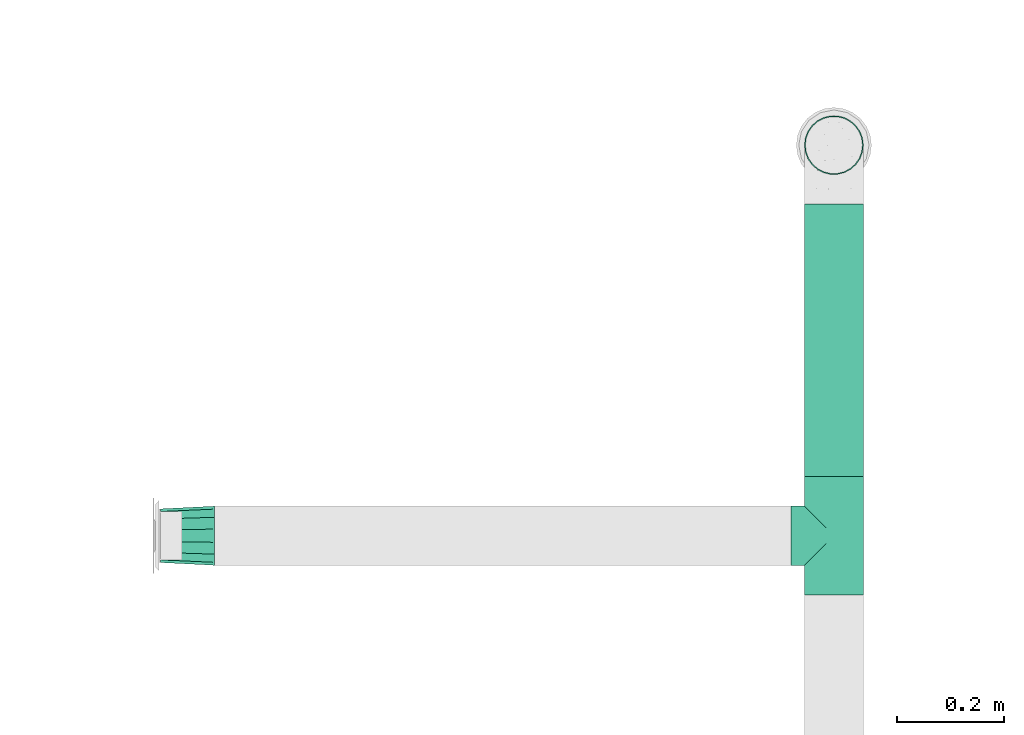
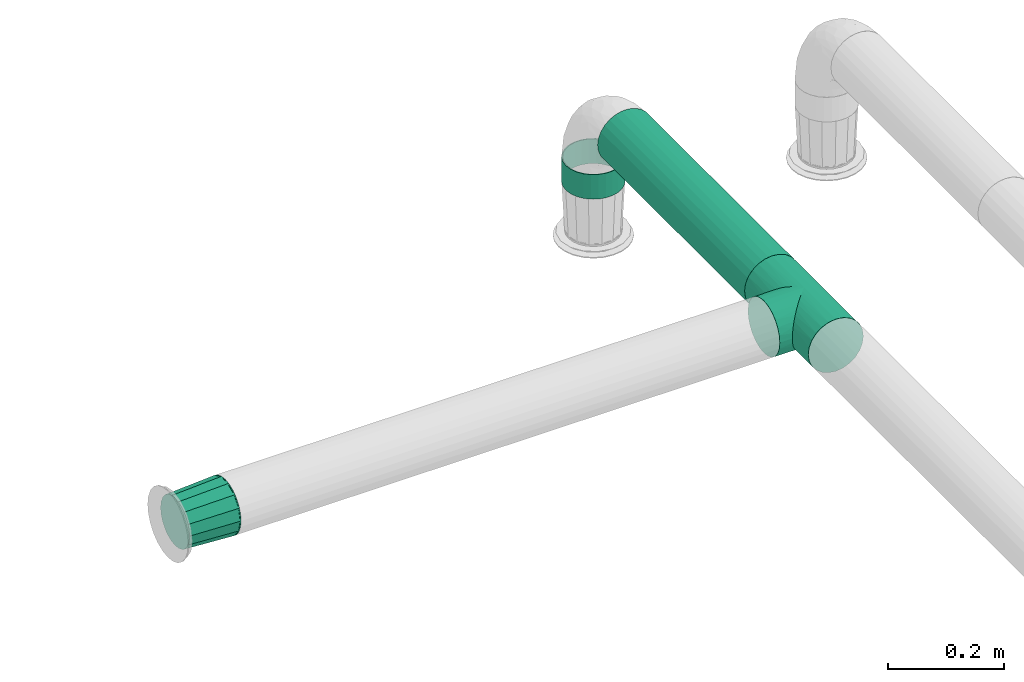
# One storey, part 72 of 115: 2 flow fittings, 2 flow segments.
"""IFC2X3 building model written with IfcOpenShell, lengths in millimetres."""

from ifc_helpers import new_model, entity, si_unit, converted_unit, derived_unit, direction, frame, origin_with_axes, origin_2d_with_axis, place, context, subcontext, project, spatial, hollow_circle, extrude, open_shell, surface_model, source, transform, mapped, material, layer, layer_set, layer_usage, type_object, element, save


model = new_model("IFC2X3")

# Units and contexts
model_context = context("Model", 3, precision=1e-05, world=origin_with_axes(), true_north=direction((0.0, 1.0)))
body_context = subcontext(model_context, "Body", "Model", "MODEL_VIEW")
ifc_project = project(units=[si_unit("AREAUNIT", "SQUARE_METRE"), si_unit("VOLUMEUNIT", "CUBIC_METRE", prefix="DECI"), si_unit("TIMEUNIT", "SECOND"), si_unit("THERMODYNAMICTEMPERATUREUNIT", "DEGREE_CELSIUS"), si_unit("PRESSUREUNIT", "PASCAL"), si_unit("MASSUNIT", "GRAM", prefix="KILO"), si_unit("LENGTHUNIT", "METRE", prefix="MILLI"), si_unit("POWERUNIT", "WATT"), si_unit("ELECTRICCURRENTUNIT", "AMPERE"), si_unit("ELECTRICVOLTAGEUNIT", "VOLT"), derived_unit("VOLUMETRICFLOWRATEUNIT", [(si_unit("VOLUMEUNIT", "CUBIC_METRE", prefix="DECI"), 1), (si_unit("TIMEUNIT", "SECOND"), -1)]), derived_unit("LINEARVELOCITYUNIT", [(si_unit("LENGTHUNIT", "METRE"), 1), (si_unit("TIMEUNIT", "SECOND"), -1)]), derived_unit("MASSDENSITYUNIT", [(si_unit("MASSUNIT", "GRAM", prefix="KILO"), 1), (si_unit("VOLUMEUNIT", "CUBIC_METRE"), -1)]), converted_unit("PLANEANGLEUNIT", "DEGREE", entity("IfcRatioMeasure", 0.01745), si_unit("PLANEANGLEUNIT", "RADIAN"), dimensions=[0, 0, 0, 0, 0, 0, 0])], contexts=[model_context])

# Site, building, storey
site_placement = place(None, origin_with_axes())
site = spatial("IfcSite", under=ifc_project, at=site_placement, CompositionType="ELEMENT")
building_placement = place(site_placement, origin_with_axes())
building = spatial("IfcBuilding", under=site, at=building_placement, Name="mc-building", CompositionType="ELEMENT")
storey_placement = place(building_placement, frame((0.0, 0.0, 2950.0), z_axis=(0.0, 0.0, 1.0), x_axis=(1.0, 0.0, 0.0)))
storey = spatial("IfcBuildingStorey", under=building, at=storey_placement, Name="2. Korrus", CompositionType="ELEMENT", Elevation=2950.0)

# Flow segment
ifc_material = material(Name="FZ1")
ifc_layer = layer(ifc_material, 0.0)
ifc_layer_set = layer_set([ifc_layer], Name="FZ1")
ifc_layer_usage = layer_usage(ifc_layer_set, "AXIS1", "POSITIVE", 0.0)
duct_segment_type = type_object("IfcDuctSegmentType", PredefinedType="RIGIDSEGMENT")
shared_shape_1 = source(origin_with_axes(), body_context, "Body", "SweptSolid", [
    extrude(hollow_circle(Radius=55.0, WallThickness=2.0, at=origin_2d_with_axis()), frame((0.0, 0.0, 0.0), z_axis=(1.0, 0.0, 0.0), x_axis=(0.0, 1.0, 0.0)), (0.0, 0.0, 1.0), 51.9),
])
flow_segment_1_placement = place(storey_placement, frame((30053.28275, 4393.85998, 2355.0), z_axis=(0.0, -1.0, 0.0), x_axis=(0.0, 0.0, -1.0)))
element("IfcFlowSegment", 1, at=flow_segment_1_placement, inside=storey, type_object=duct_segment_type, material=ifc_layer_usage, context=body_context, shape_type="MappedRepresentation", body=[
    mapped(shared_shape_1, transform((0.0, 0.0, 0.0), scale=1.0)),
])

# Flow fittings
duct_fitting_type_1 = type_object("IfcDuctFittingType", PredefinedType="JUNCTION")
shared_shape_2 = source(origin_with_axes(), body_context, "Body", "SurfaceModel", [
    surface_model("IfcShellBasedSurfaceModel", [(-110.0, -38.89087, -38.89087), (-110.0, -55.0, 0.0), (-110.0, -27.5, -47.63139), (-110.0, -53.12592, -14.23505), (-110.0, -47.63139, -27.5), (-110.0, 47.63139, -27.5), (-110.0, 53.12592, 14.23505), (-110.0, 53.12592, -14.23505), (-110.0, 55.0, 0.0), (110.0, 38.89087, -38.89087), (110.0, 55.0, 0.0), (110.0, 27.5, -47.63139), (110.0, -38.89087, -38.89087), (110.0, -53.12592, 14.23505), (110.0, -47.63139, -27.5), (110.0, -55.0, 0.0), (110.0, -53.12592, -14.23505), (110.0, 53.12592, -14.23505), (110.0, 47.63139, -27.5), (-110.0, 38.89087, -38.89087), (-110.0, -14.23505, -53.12592), (-110.0, 0.0, -55.0), (-110.0, 27.5, -47.63139), (-110.0, 14.23505, -53.12592), (-110.0, -53.12592, 14.23505), (-110.0, -47.63139, 27.5), (-110.0, -38.89087, 38.89087), (-110.0, 14.23505, 53.12592), (-110.0, 27.5, 47.63139), (-55.0, 80.0, 0.0), (0.0, 80.0, -55.0), (-14.23505, 80.0, -53.12592), (-27.5, 80.0, -47.63139), (-38.89087, 80.0, -38.89087), (-47.63139, 80.0, -27.5), (38.89087, 80.0, -38.89087), (53.12592, 80.0, 14.23505), (27.5, 80.0, -47.63139), (14.23505, 80.0, -53.12592), (47.63139, 80.0, -27.5), (53.12592, 80.0, -14.23505), (55.0, 80.0, 0.0), (-53.12592, 80.0, -14.23505), (-53.12592, 80.0, 14.23505), (-47.63139, 80.0, 27.5), (-38.89087, 80.0, 38.89087), (0.0, 80.0, 55.0), (-27.5, 80.0, 47.63139), (-14.23505, 80.0, 53.12592), (47.63139, 80.0, 27.5), (38.89087, 80.0, 38.89087), (27.5, 80.0, 47.63139), (14.23505, 80.0, 53.12592), (-7.4066, 7.4066, 54.49901), (0.0, 0.0, 55.0), (-21.93978, 21.93978, 50.43457), (-14.74521, 14.74521, 52.98659), (-35.50357, 35.50357, 42.00591), (-28.89905, 28.89905, 46.79578), (-46.92319, 46.92319, 28.69171), (-41.58668, 41.58668, 35.99373), (-54.01174, 54.01174, 10.37938), (-54.06296, 80.0, 7.11752), (-55.0, 55.0, 0.0), (-51.19777, 51.19777, 20.0945), (-50.37866, 80.0, 20.86752), (-51.19777, 51.19777, -20.0945), (-54.01174, 54.01174, -10.37938), (-50.37866, 80.0, -20.86752), (-41.58668, 41.58668, -35.99373), (-46.92319, 46.92319, -28.69171), (-54.06296, 80.0, -7.11752), (-35.50357, 35.50357, -42.00591), (-14.74521, 14.74521, -52.98659), (-21.93978, 21.93978, -50.43457), (0.0, 0.0, -55.0), (-7.4066, 7.4066, -54.49901), (-28.89905, 28.89905, -46.79578), (7.4066, 7.4066, -54.49901), (21.93978, 21.93978, -50.43457), (14.74521, 14.74521, -52.98659), (35.50357, 35.50357, -42.00591), (28.89905, 28.89905, -46.79578), (46.92319, 46.92319, -28.69171), (41.58668, 41.58668, -35.99373), (54.01174, 54.01174, -10.37938), (54.06296, 80.0, -7.11752), (55.0, 55.0, 0.0), (51.19777, 51.19777, -20.0945), (50.37866, 80.0, -20.86752), (51.19777, 51.19777, 20.0945), (54.01174, 54.01174, 10.37938), (50.37866, 80.0, 20.86752), (41.58668, 41.58668, 35.99373), (46.92319, 46.92319, 28.69171), (54.06296, 80.0, 7.11752), (35.50357, 35.50357, 42.00591), (14.74521, 14.74521, 52.98659), (21.93978, 21.93978, 50.43457), (7.4066, 7.4066, 54.49901), (28.89905, 28.89905, 46.79578), (-110.0, -27.5, 47.63139), (-110.0, 0.0, 55.0), (-110.0, -14.23505, 53.12592), (-110.0, 47.63139, 27.5), (-110.0, 38.89087, 38.89087), (110.0, 0.0, -55.0), (110.0, 14.23505, -53.12592), (110.0, -14.23505, -53.12592), (110.0, -27.5, -47.63139), (110.0, 53.12592, 14.23505), (110.0, -47.63139, 27.5), (110.0, -38.89087, 38.89087), (110.0, 14.23505, 53.12592), (110.0, -27.5, 47.63139), (110.0, -14.23505, 53.12592), (110.0, 47.63139, 27.5), (110.0, 38.89087, 38.89087), (110.0, 27.5, 47.63139), (110.0, 0.0, 55.0)], [open_shell([[[0, 1, 2]], [[3, 1, 4]], [[5, 6, 7]], [[8, 7, 6]], [[9, 10, 11]], [[12, 13, 14]], [[15, 16, 13]], [[17, 10, 18]], [[19, 6, 5]], [[2, 1, 20]], [[19, 21, 6]], [[21, 19, 22]], [[22, 23, 21]], [[24, 25, 21]], [[21, 25, 26]], [[27, 28, 21]], [[29, 30, 31]], [[32, 29, 31]], [[29, 33, 34]], [[29, 32, 33]], [[35, 30, 36]], [[30, 35, 37]], [[37, 38, 30]], [[35, 36, 39]], [[39, 36, 40]], [[41, 40, 36]], [[42, 29, 34]], [[43, 44, 30]], [[30, 44, 45]], [[46, 30, 47]], [[30, 45, 47]], [[46, 47, 48]], [[49, 36, 30]], [[50, 49, 30]], [[51, 50, 30]], [[52, 51, 30]], [[52, 30, 46]], [[29, 43, 30]], [[46, 53, 54]], [[48, 55, 56]], [[48, 56, 53]], [[48, 53, 46]], [[57, 58, 47]], [[55, 48, 47]], [[45, 57, 47]], [[55, 47, 58]], [[44, 59, 60]], [[61, 62, 63]], [[43, 61, 64]], [[65, 43, 64]], [[44, 64, 59]], [[44, 60, 45]], [[43, 62, 61]], [[64, 44, 65]], [[29, 63, 62]], [[57, 45, 60]], [[42, 66, 67]], [[68, 34, 66]], [[34, 69, 70]], [[71, 42, 67]], [[34, 70, 66]], [[63, 71, 67]], [[29, 71, 63]], [[68, 66, 42]], [[34, 33, 69]], [[33, 72, 69]], [[31, 73, 74]], [[30, 75, 76]], [[31, 76, 73]], [[32, 77, 72]], [[77, 32, 74]], [[32, 31, 74]], [[31, 30, 76]], [[33, 32, 72]], [[30, 78, 75]], [[38, 79, 80]], [[38, 80, 78]], [[38, 78, 30]], [[81, 82, 37]], [[79, 38, 37]], [[35, 81, 37]], [[79, 37, 82]], [[39, 83, 84]], [[85, 86, 87]], [[40, 85, 88]], [[89, 40, 88]], [[39, 88, 83]], [[39, 84, 35]], [[40, 86, 85]], [[88, 39, 89]], [[41, 87, 86]], [[81, 35, 84]], [[36, 90, 91]], [[92, 49, 90]], [[49, 93, 94]], [[95, 36, 91]], [[49, 94, 90]], [[87, 95, 91]], [[95, 87, 41]], [[36, 92, 90]], [[49, 50, 93]], [[50, 96, 93]], [[52, 97, 98]], [[46, 54, 99]], [[52, 99, 97]], [[51, 100, 96]], [[100, 51, 98]], [[51, 52, 98]], [[52, 46, 99]], [[50, 51, 96]], [[1, 21, 20]], [[1, 0, 4]], [[101, 102, 26]], [[102, 21, 26]], [[102, 101, 103]], [[104, 6, 21]], [[105, 104, 21]], [[105, 21, 28]], [[21, 102, 27]], [[1, 24, 21]], [[106, 107, 108]], [[108, 13, 109]], [[109, 13, 12]], [[108, 10, 110]], [[107, 11, 10]], [[9, 18, 10]], [[10, 108, 107]], [[16, 14, 13]], [[108, 111, 13]], [[108, 112, 111]], [[108, 113, 114]], [[114, 112, 108]], [[113, 115, 114]], [[108, 110, 116]], [[108, 116, 117]], [[108, 117, 118]], [[113, 108, 118]], [[113, 119, 115]], [[115, 119, 54]], [[114, 115, 101]], [[103, 54, 102]], [[115, 54, 103]], [[103, 101, 115]], [[101, 26, 114]], [[111, 112, 25]], [[13, 111, 24]], [[15, 13, 1]], [[25, 112, 26]], [[24, 111, 25]], [[24, 1, 13]], [[114, 26, 112]], [[16, 15, 3]], [[14, 16, 4]], [[3, 15, 1]], [[4, 16, 3]], [[4, 0, 14]], [[0, 12, 14]], [[109, 12, 2]], [[108, 109, 20]], [[106, 108, 75]], [[20, 109, 2]], [[20, 21, 75]], [[20, 75, 108]], [[0, 2, 12]], [[21, 76, 75]], [[23, 74, 73]], [[23, 73, 76]], [[23, 76, 21]], [[72, 77, 22]], [[74, 23, 22]], [[19, 72, 22]], [[74, 22, 77]], [[5, 70, 69]], [[7, 67, 66]], [[5, 66, 70]], [[5, 69, 19]], [[7, 8, 67]], [[66, 5, 7]], [[63, 67, 8]], [[72, 19, 69]], [[107, 106, 78]], [[79, 11, 107]], [[9, 11, 81]], [[11, 82, 81]], [[106, 75, 78]], [[107, 80, 79]], [[11, 79, 82]], [[80, 107, 78]], [[18, 9, 84]], [[17, 18, 88]], [[10, 17, 85]], [[18, 84, 83]], [[17, 88, 85]], [[10, 85, 87]], [[88, 18, 83]], [[81, 84, 9]], [[110, 10, 91]], [[116, 110, 90]], [[117, 116, 93]], [[10, 87, 91]], [[116, 90, 94]], [[116, 94, 93]], [[90, 110, 91]], [[93, 96, 117]], [[118, 96, 100]], [[117, 96, 118]], [[113, 118, 98]], [[119, 113, 99]], [[118, 100, 98]], [[113, 97, 99]], [[119, 99, 54]], [[97, 113, 98]], [[6, 64, 61]], [[104, 60, 59]], [[104, 59, 64]], [[8, 61, 63]], [[61, 8, 6]], [[6, 104, 64]], [[104, 105, 60]], [[105, 57, 60]], [[27, 56, 55]], [[102, 54, 53]], [[27, 53, 56]], [[28, 58, 57]], [[58, 28, 55]], [[28, 27, 55]], [[27, 102, 53]], [[105, 28, 57]]])]),
])
flow_fitting_1_placement = place(storey_placement, frame((30053.28275, 3666.26111, 2465.0), z_axis=(0.0, 0.0, 1.0), x_axis=(0.0, 1.0, 0.0)))
element("IfcFlowFitting", 2, at=flow_fitting_1_placement, inside=storey, type_object=duct_fitting_type_1, context=body_context, shape_type="MappedRepresentation", body=[
    mapped(shared_shape_2, transform((0.0, 0.0, 0.0), scale=1.0)),
])
duct_fitting_type_2 = type_object("IfcDuctFittingType", PredefinedType="TRANSITION")
shared_shape_3 = source(origin_with_axes(), body_context, "Body", "SurfaceModel", [
    surface_model("IfcShellBasedSurfaceModel", [(100.0, -55.0, 0.0), (100.0, -12.23865, 53.62104), (100.0, -34.29194, 43.00073), (100.0, 49.55329, 23.86361), (100.0, 34.29194, 43.00073), (100.0, 49.55329, -23.86361), (0.0, -45.04844, -21.69419), (0.0, -50.0, 0.0), (0.0, -45.04844, 21.69419), (0.0, 31.17449, 39.09157), (0.0, 45.04844, 21.69419), (0.0, 50.0, 0.0), (98.0, 47.63139, 27.5), (98.0, 0.0, 55.0), (98.0, 38.89087, 38.89087), (98.0, -38.89087, 38.89087), (98.0, -47.63139, 27.5), (100.0, 12.23865, 53.62104), (100.0, -49.55329, 23.86361), (100.0, 55.0, 0.0), (100.0, 12.23865, -53.62104), (100.0, 34.29194, -43.00073), (100.0, -49.55329, -23.86361), (100.0, -34.29194, -43.00073), (100.0, -12.23865, -53.62104), (0.0, -31.17449, 39.09157), (0.0, -11.12605, 48.7464), (0.0, 11.12605, 48.7464), (0.0, -31.17449, -39.09157), (0.0, 11.12605, -48.7464), (0.0, -11.12605, -48.7464), (0.0, 45.04844, -21.69419), (0.0, 31.17449, -39.09157), (0.0, 47.52422, -10.84709), (0.0, 38.11147, -30.39288), (100.0, 41.92261, -33.43217), (100.0, -41.92261, -33.43217), (0.0, -38.11147, -30.39288), (100.0, 23.2653, -48.31088), (0.0, 21.15027, -43.91899), (100.0, 52.32388, -11.72483), (0.0, 0.0, -48.7464), (100.0, 0.0, -53.62104), (0.0, -21.15027, -43.91899), (100.0, -23.2653, -48.31088), (0.0, -47.52422, -10.84709), (100.0, -52.32388, -11.72483), (0.0, -47.52422, 10.84709), (0.0, -38.11147, 30.39288), (100.0, -41.92261, 33.43217), (100.0, 41.92261, 33.43217), (0.0, 38.11147, 30.39288), (100.0, -23.2653, 48.31088), (0.0, -21.15027, 43.91899), (100.0, -52.32388, 11.72483), (0.0, 0.0, 48.7464), (100.0, 0.0, 53.62104), (0.0, 21.15027, 43.91899), (100.0, 23.2653, 48.31088), (0.0, 47.52422, 10.84709), (100.0, 52.32388, 11.72483), (100.0, -14.23505, -53.12592), (100.0, 0.0, -55.0), (100.0, -27.5, -47.63139), (100.0, 27.5, -47.63139), (100.0, -38.89087, -38.89087), (100.0, -53.12592, -14.23505), (100.0, -47.63139, -27.5), (100.0, -47.63139, 27.5), (100.0, 14.23505, -53.12592), (100.0, 38.89087, -38.89087), (100.0, 47.63139, -27.5), (100.0, 47.63139, 27.5), (100.0, 53.12592, -14.23505), (100.0, -53.12592, 14.23505), (100.0, -38.89087, 38.89087), (100.0, -27.5, 47.63139), (100.0, 0.0, 55.0), (100.0, -14.23505, 53.12592), (100.0, 53.12592, 14.23505), (100.0, 38.89087, 38.89087), (100.0, 27.5, 47.63139), (100.0, 14.23505, 53.12592), (98.0, -27.5, 47.63139), (98.0, -14.23505, 53.12592), (98.0, -53.12592, -14.23505), (98.0, 14.23505, 53.12592), (98.0, 27.5, 47.63139), (98.0, 53.12592, 14.23505), (98.0, 55.0, 0.0), (98.0, -47.63139, -27.5), (98.0, -53.12592, 14.23505), (98.0, 27.5, -47.63139), (98.0, -27.5, -47.63139), (98.0, -38.89087, -38.89087), (98.0, 0.0, -55.0), (98.0, -14.23505, -53.12592), (98.0, 38.89087, -38.89087), (98.0, 47.63139, -27.5), (98.0, 53.12592, -14.23505), (98.0, 14.23505, -53.12592), (98.0, -55.0, 0.0), (0.0, 0.0, 50.0), (0.0, 35.35534, 35.35534), (0.0, -12.94095, 48.29629), (0.0, -25.0, 43.30127), (0.0, -35.35534, 35.35534), (0.0, -48.29629, 12.94095), (0.0, -43.30127, 25.0), (0.0, 25.0, 43.30127), (0.0, 12.94095, 48.29629), (0.0, 43.30127, 25.0), (0.0, 48.29629, 12.94095), (0.0, 25.0, -43.30127), (0.0, 48.29629, -12.94095), (0.0, -48.29629, -12.94095), (0.0, -43.30127, -25.0), (0.0, -12.94095, -48.29629), (0.0, -25.0, -43.30127), (0.0, -35.35534, -35.35534), (0.0, 43.30127, -25.0), (0.0, 35.35534, -35.35534), (0.0, 12.94095, -48.29629), (0.0, 0.0, -50.0), (2.0, -35.35534, -35.35534), (2.0, -25.0, -43.30127), (2.0, -12.94095, -48.29629), (2.0, -43.30127, -25.0), (2.0, 0.0, -50.0), (2.0, -48.29629, -12.94095), (2.0, -50.0, 0.0), (2.0, 12.94095, -48.29629), (2.0, 25.0, -43.30127), (2.0, 43.30127, -25.0), (2.0, 48.29629, -12.94095), (2.0, 35.35534, -35.35534), (2.0, -48.29629, 12.94095), (2.0, -35.35534, 35.35534), (2.0, -43.30127, 25.0), (2.0, 35.35534, 35.35534), (2.0, -12.94095, 48.29629), (2.0, -25.0, 43.30127), (2.0, 0.0, 50.0), (2.0, 43.30127, 25.0), (2.0, 48.29629, 12.94095), (2.0, 50.0, 0.0), (2.0, 25.0, 43.30127), (2.0, 12.94095, 48.29629)], [open_shell([[[0, 1, 2]], [[3, 4, 5]], [[6, 7, 8]], [[9, 10, 11]], [[12, 13, 14]], [[15, 13, 16]], [[0, 4, 17]], [[2, 18, 0]], [[1, 0, 17]], [[3, 5, 19]], [[20, 21, 5]], [[22, 20, 5]], [[22, 5, 0]], [[22, 23, 24]], [[22, 24, 20]], [[4, 0, 5]], [[8, 25, 6]], [[6, 25, 26]], [[6, 26, 27]], [[11, 27, 9]], [[28, 6, 29]], [[30, 28, 29]], [[31, 6, 11]], [[31, 32, 29]], [[31, 29, 6]], [[27, 11, 6]], [[31, 33, 5]], [[34, 35, 32]], [[36, 22, 6]], [[36, 37, 23]], [[38, 29, 39]], [[33, 40, 5]], [[33, 11, 40]], [[19, 40, 11]], [[32, 21, 39]], [[32, 35, 21]], [[34, 31, 35]], [[30, 41, 42]], [[28, 43, 44]], [[42, 41, 20]], [[7, 45, 46]], [[38, 39, 21]], [[46, 0, 7]], [[6, 37, 36]], [[38, 20, 29]], [[43, 30, 24]], [[42, 24, 30]], [[28, 23, 37]], [[6, 22, 45]], [[35, 31, 5]], [[44, 43, 24]], [[20, 41, 29]], [[46, 45, 22]], [[44, 23, 28]], [[8, 47, 18]], [[48, 49, 25]], [[50, 3, 10]], [[50, 51, 4]], [[52, 26, 53]], [[47, 54, 18]], [[47, 7, 54]], [[0, 54, 7]], [[25, 2, 53]], [[25, 49, 2]], [[48, 8, 49]], [[27, 55, 56]], [[9, 57, 58]], [[56, 55, 1]], [[11, 59, 60]], [[52, 53, 2]], [[60, 19, 11]], [[10, 51, 50]], [[52, 1, 26]], [[57, 27, 17]], [[56, 17, 27]], [[9, 4, 51]], [[10, 3, 59]], [[49, 8, 18]], [[58, 57, 17]], [[1, 55, 26]], [[60, 59, 3]], [[58, 4, 9]], [[61, 62, 63]], [[63, 64, 65]], [[66, 67, 68]], [[65, 64, 67]], [[67, 64, 68]], [[69, 64, 62]], [[64, 63, 62]], [[70, 71, 64]], [[72, 64, 71]], [[71, 73, 19]], [[74, 0, 66]], [[72, 68, 64]], [[75, 68, 76]], [[77, 78, 76]], [[72, 76, 68]], [[76, 72, 77]], [[79, 72, 19]], [[19, 72, 71]], [[80, 81, 77]], [[77, 72, 80]], [[82, 77, 81]], [[74, 66, 68]], [[83, 84, 13]], [[15, 83, 13]], [[12, 16, 13]], [[16, 12, 85]], [[86, 87, 13]], [[87, 14, 13]], [[88, 89, 12]], [[89, 90, 12]], [[91, 16, 85]], [[90, 85, 12]], [[89, 92, 90]], [[93, 94, 95]], [[95, 94, 90]], [[96, 93, 95]], [[97, 92, 98]], [[98, 89, 99]], [[100, 95, 92]], [[92, 89, 98]], [[90, 92, 95]], [[101, 91, 85]], [[89, 73, 99]], [[99, 71, 98]], [[92, 97, 64]], [[70, 97, 98]], [[100, 92, 69]], [[73, 71, 99]], [[89, 19, 73]], [[92, 64, 69]], [[64, 97, 70]], [[98, 71, 70]], [[100, 69, 62]], [[62, 95, 100]], [[95, 61, 96]], [[96, 63, 93]], [[90, 94, 67]], [[65, 94, 93]], [[85, 90, 66]], [[63, 65, 93]], [[96, 61, 63]], [[85, 66, 0]], [[66, 90, 67]], [[94, 65, 67]], [[85, 0, 101]], [[62, 61, 95]], [[101, 74, 91]], [[91, 68, 16]], [[83, 15, 76]], [[75, 15, 16]], [[84, 83, 78]], [[74, 68, 91]], [[101, 0, 74]], [[83, 76, 78]], [[76, 15, 75]], [[16, 68, 75]], [[84, 78, 77]], [[77, 13, 84]], [[13, 82, 86]], [[86, 81, 87]], [[12, 14, 72]], [[80, 14, 87]], [[88, 12, 79]], [[81, 80, 87]], [[86, 82, 81]], [[88, 79, 19]], [[79, 12, 72]], [[14, 80, 72]], [[88, 19, 89]], [[77, 82, 13]], [[102, 103, 104]], [[105, 104, 106]], [[107, 108, 106]], [[103, 106, 104]], [[106, 103, 107]], [[109, 103, 110]], [[103, 102, 110]], [[111, 112, 103]], [[113, 103, 112]], [[112, 11, 114]], [[107, 103, 113]], [[113, 115, 107]], [[116, 115, 117]], [[117, 118, 119]], [[116, 117, 119]], [[117, 115, 113]], [[120, 121, 114]], [[113, 114, 121]], [[113, 122, 117]], [[113, 112, 114]], [[117, 122, 123]], [[7, 107, 115]], [[124, 125, 126]], [[127, 124, 126]], [[128, 129, 126]], [[127, 126, 129]], [[130, 129, 128]], [[131, 132, 128]], [[132, 130, 128]], [[133, 134, 135]], [[132, 135, 134]], [[132, 134, 130]], [[134, 136, 130]], [[137, 138, 136]], [[137, 136, 139]], [[140, 137, 139]], [[141, 137, 140]], [[142, 140, 139]], [[143, 139, 144]], [[144, 134, 145]], [[146, 147, 139]], [[139, 136, 144]], [[139, 147, 142]], [[136, 134, 144]], [[11, 134, 114]], [[114, 133, 120]], [[113, 121, 132]], [[135, 121, 120]], [[122, 113, 131]], [[134, 133, 114]], [[11, 145, 134]], [[113, 132, 131]], [[132, 121, 135]], [[120, 133, 135]], [[122, 131, 128]], [[128, 123, 122]], [[123, 126, 117]], [[117, 125, 118]], [[116, 119, 127]], [[124, 119, 118]], [[115, 116, 129]], [[125, 124, 118]], [[117, 126, 125]], [[115, 129, 130]], [[129, 116, 127]], [[119, 124, 127]], [[115, 130, 7]], [[128, 126, 123]], [[7, 136, 107]], [[107, 138, 108]], [[105, 106, 141]], [[137, 106, 108]], [[104, 105, 140]], [[136, 138, 107]], [[7, 130, 136]], [[105, 141, 140]], [[141, 106, 137]], [[108, 138, 137]], [[104, 140, 142]], [[142, 102, 104]], [[102, 147, 110]], [[110, 146, 109]], [[111, 103, 143]], [[139, 103, 109]], [[112, 111, 144]], [[146, 139, 109]], [[110, 147, 146]], [[112, 144, 145]], [[144, 111, 143]], [[103, 139, 143]], [[112, 145, 11]], [[142, 147, 102]]])]),
])
flow_fitting_2_placement = place(storey_placement, frame((28799.07051, 3666.26111, 2465.0), z_axis=(0.0, 0.0, 1.0), x_axis=(1.0, 0.0, 0.0)))
element("IfcFlowFitting", 3, at=flow_fitting_2_placement, inside=storey, type_object=duct_fitting_type_2, context=body_context, shape_type="MappedRepresentation", body=[
    mapped(shared_shape_3, transform((0.0, 0.0, 0.0), scale=1.0)),
])

# Flow segment
shared_shape_4 = source(origin_with_axes(), body_context, "Body", "SweptSolid", [
    extrude(hollow_circle(Radius=55.0, WallThickness=2.0, at=origin_2d_with_axis()), frame((0.0, 0.0, 0.0), z_axis=(1.0, 0.0, 0.0), x_axis=(0.0, 1.0, 0.0)), (0.0, 0.0, 1.0), 507.6),
])
flow_segment_2_placement = place(storey_placement, frame((30053.28275, 3776.26111, 2465.0), z_axis=(0.0, 0.0, 1.0), x_axis=(0.0, 1.0, 0.0)))
element("IfcFlowSegment", 4, at=flow_segment_2_placement, inside=storey, type_object=duct_segment_type, material=ifc_layer_usage, context=body_context, shape_type="MappedRepresentation", body=[
    mapped(shared_shape_4, transform((0.0, 0.0, 0.0), scale=1.0)),
])

save(model, "model.ifc")
